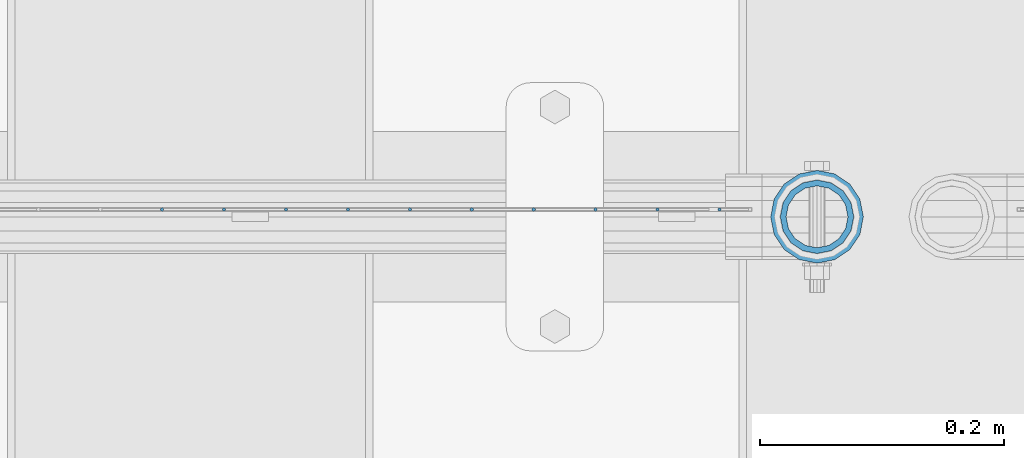
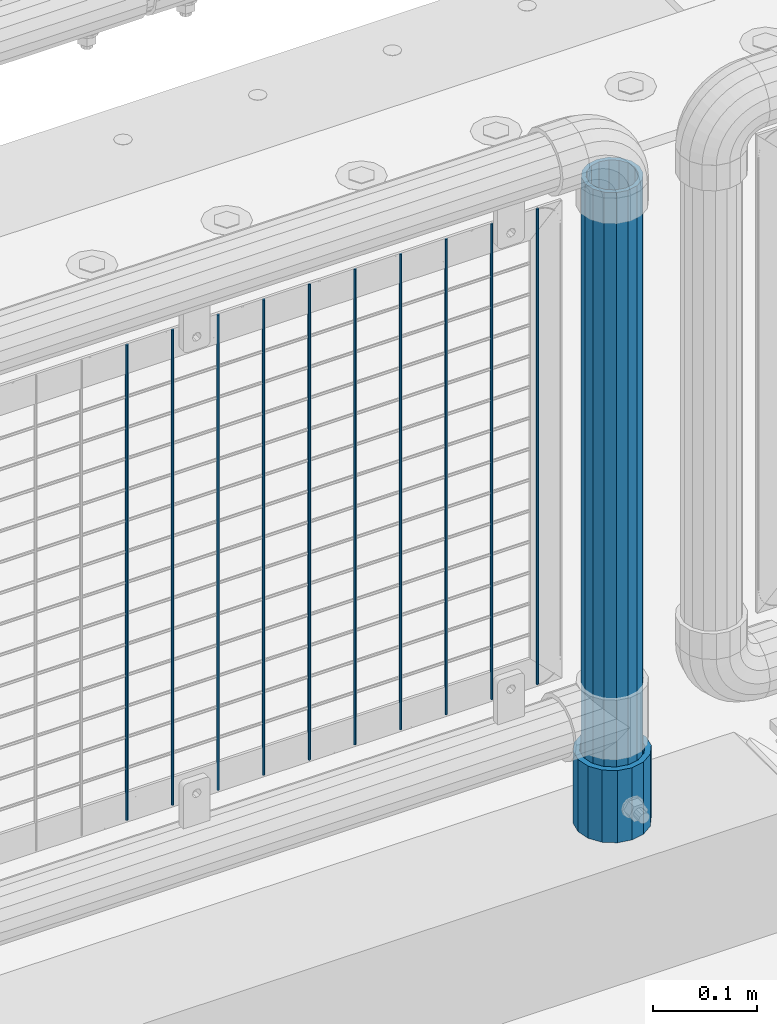
# One storey, part 108 of 270: 12 columns.
"""IFC2X3 building model written with IfcOpenShell, lengths in millimetres."""

from ifc_helpers import new_model, si_unit, frame, origin_with_axes, place, context, subcontext, project, spatial, faceted_brep, material, type_object, element, save


model = new_model("IFC2X3")

# Units and contexts
model_context = context("Model", 3, precision=1e-05, world=origin_with_axes())
body_context = subcontext(model_context, "Body", "Model", "MODEL_VIEW")
ifc_project = project(units=[si_unit("LENGTHUNIT", "METRE", prefix="MILLI"), si_unit("AREAUNIT", "SQUARE_METRE"), si_unit("VOLUMEUNIT", "CUBIC_METRE"), si_unit("MASSUNIT", "GRAM", prefix="KILO"), si_unit("TIMEUNIT", "SECOND"), si_unit("PLANEANGLEUNIT", "RADIAN"), si_unit("SOLIDANGLEUNIT", "STERADIAN"), si_unit("THERMODYNAMICTEMPERATUREUNIT", "DEGREE_CELSIUS"), si_unit("LUMINOUSINTENSITYUNIT", "LUMEN")], contexts=[model_context])

# Site, building, storey
site_placement = place(None, origin_with_axes())
site = spatial("IfcSite", under=ifc_project, at=site_placement, CompositionType="ELEMENT")
building_placement = place(site_placement, origin_with_axes())
building = spatial("IfcBuilding", under=site, at=building_placement, Name="Standard", CompositionType="ELEMENT")
storey_placement = place(building_placement, origin_with_axes())
storey = spatial("IfcBuildingStorey", under=building, at=storey_placement, Name="Undefined", CompositionType="ELEMENT", Elevation=0.0)

# Columns
ifc_material_1 = material()
column_type_1 = type_object("IfcColumnType", PredefinedType="NOTDEFINED")
column_1_placement = place(storey_placement, frame((18583.9999998042, -16335.5, 168.019999999998), z_axis=(-1.0, 0.0, 0.0), x_axis=(0.0, 0.0, 1.0)))
element("IfcColumn", 1, at=column_1_placement, inside=storey, type_object=column_type_1, material=ifc_material_1, context=body_context, shape_type="Brep", body=[
    faceted_brep([(0.0, -25.3500000000004, 0.0), (0.0, -23.4203461491616, 9.70102501045403), (760.0, -23.4203461491616, 9.70102501045403), (760.0, -25.3500000000004, 0.0), (0.0, -17.9251569030785, 17.9251569030785), (760.0, -17.9251569030785, 17.9251569030785), (0.0, -9.70102501045585, 23.4203461491597), (760.0, -9.70102501045585, 23.4203461491597), (0.0, 0.0, 25.3499999999985), (760.0, 0.0, 25.3499999999985), (0.0, 9.70102501045585, 23.4203461491597), (760.0, 9.70102501045585, 23.4203461491597), (0.0, 17.9251569030785, 17.9251569030785), (760.0, 17.9251569030785, 17.9251569030785), (0.0, 23.4203461491616, 9.70102501045403), (760.0, 23.4203461491616, 9.70102501045403), (0.0, 25.3500000000004, 0.0), (760.0, 25.3500000000004, 0.0), (0.0, 23.4203461491616, -9.70102501045403), (760.0, 23.4203461491616, -9.70102501045403), (0.0, 17.9251569030785, -17.9251569030785), (760.0, 17.9251569030785, -17.9251569030785), (0.0, 9.70102501045585, -23.4203461491597), (760.0, 9.70102501045585, -23.4203461491597), (0.0, 0.0, -25.3499999999985), (760.0, 0.0, -25.3499999999985), (0.0, -9.70102501045585, -23.4203461491597), (760.0, -9.70102501045585, -23.4203461491597), (0.0, -17.9251569030785, -17.9251569030785), (760.0, -17.9251569030785, -17.9251569030785), (0.0, -23.4203461491616, -9.70102501045403), (760.0, -23.4203461491616, -9.70102501045403), (0.0, -30.1499999999996, 0.0), (0.0, -27.8549679052157, -11.5379054858058), (760.0, -27.8549679052157, -11.5379054858058), (760.0, -30.1499999999996, 0.0), (0.0, -21.3192694527752, -21.3192694527752), (760.0, -21.3192694527752, -21.3192694527752), (0.0, -11.5379054858076, -27.8549679052157), (760.0, -11.5379054858076, -27.8549679052157), (0.0, 0.0, -30.1500000000015), (760.0, 0.0, -30.1500000000015), (0.0, 11.5379054858076, -27.8549679052157), (760.0, 11.5379054858076, -27.8549679052157), (0.0, 21.3192694527752, -21.3192694527752), (760.0, 21.3192694527752, -21.3192694527752), (0.0, 27.8549679052157, -11.5379054858058), (760.0, 27.8549679052157, -11.5379054858058), (0.0, 30.1499999999996, 0.0), (760.0, 30.1499999999996, 0.0), (0.0, 27.8549679052157, 11.5379054858058), (760.0, 27.8549679052157, 11.5379054858058), (0.0, 21.3192694527752, 21.3192694527752), (760.0, 21.3192694527752, 21.3192694527752), (0.0, 11.5379054858076, 27.8549679052157), (760.0, 11.5379054858076, 27.8549679052157), (0.0, 0.0, 30.1500000000015), (760.0, 0.0, 30.1500000000015), (0.0, -11.5379054858076, 27.8549679052157), (760.0, -11.5379054858076, 27.8549679052157), (0.0, -21.3192694527752, 21.3192694527752), (760.0, -21.3192694527752, 21.3192694527752), (0.0, -27.8549679052157, 11.5379054858058), (760.0, -27.8549679052157, 11.5379054858058)], [[[0, 1, 2, 3]], [[1, 4, 5, 2]], [[4, 6, 7, 5]], [[6, 8, 9, 7]], [[8, 10, 11, 9]], [[10, 12, 13, 11]], [[12, 14, 15, 13]], [[14, 16, 17, 15]], [[16, 18, 19, 17]], [[18, 20, 21, 19]], [[20, 22, 23, 21]], [[22, 24, 25, 23]], [[24, 26, 27, 25]], [[26, 28, 29, 27]], [[28, 30, 31, 29]], [[30, 0, 3, 31]], [[32, 33, 34, 35]], [[33, 36, 37, 34]], [[36, 38, 39, 37]], [[38, 40, 41, 39]], [[40, 42, 43, 41]], [[42, 44, 45, 43]], [[44, 46, 47, 45]], [[46, 48, 49, 47]], [[48, 50, 51, 49]], [[50, 52, 53, 51]], [[52, 54, 55, 53]], [[54, 56, 57, 55]], [[56, 58, 59, 57]], [[58, 60, 61, 59]], [[60, 62, 63, 61]], [[62, 32, 35, 63]], [[37, 39, 41, 43, 45, 47, 49, 51, 53, 55, 57, 59, 61, 63, 35, 34], [5, 7, 9, 11, 13, 15, 17, 19, 21, 23, 25, 27, 29, 31, 3, 2]], [[62, 60, 58, 56, 54, 52, 50, 48, 46, 44, 42, 40, 38, 36, 33, 32], [30, 28, 26, 24, 22, 20, 18, 16, 14, 12, 10, 8, 6, 4, 1, 0]]]),
])
column_type_2 = type_object("IfcColumnType", PredefinedType="NOTDEFINED")
column_2_placement = place(storey_placement, frame((18583.9999998042, -16335.5, 168.019999999998), z_axis=(0.0, 1.0, 0.0), x_axis=(0.0, 0.0, 1.0)))
element("IfcColumn", 2, at=column_2_placement, inside=storey, type_object=column_type_2, material=ifc_material_1, context=body_context, shape_type="Brep", body=[
    faceted_brep([(0.0, -31.75, 0.0), (0.0, -29.3331751572332, 12.1501989775916), (85.0, -29.3331751572332, 12.1501989775916), (85.0, -31.75, 0.0), (0.0, -22.4506403026717, 22.4506403026735), (85.0, -22.4506403026717, 22.4506403026735), (0.0, -12.1501989775934, 29.3331751572332), (85.0, -12.1501989775934, 29.3331751572332), (0.0, 0.0, 31.75), (85.0, 0.0, 31.75), (0.0, 12.1501989775934, 29.3331751572332), (85.0, 12.1501989775934, 29.3331751572332), (0.0, 22.4506403026717, 22.4506403026735), (85.0, 22.4506403026717, 22.4506403026735), (0.0, 29.3331751572332, 12.1501989775916), (85.0, 29.3331751572332, 12.1501989775916), (0.0, 31.75, 0.0), (85.0, 31.75, 0.0), (0.0, 29.3331751572332, -12.1501989775916), (85.0, 29.3331751572332, -12.1501989775916), (0.0, 22.4506403026717, -22.4506403026735), (85.0, 22.4506403026717, -22.4506403026735), (0.0, 12.1501989775934, -29.3331751572332), (85.0, 12.1501989775934, -29.3331751572332), (0.0, 0.0, -31.75), (85.0, 0.0, -31.75), (0.0, -12.1501989775934, -29.3331751572332), (85.0, -12.1501989775934, -29.3331751572332), (0.0, -22.4506403026717, -22.4506403026735), (85.0, -22.4506403026717, -22.4506403026735), (0.0, -29.3331751572332, -12.1501989775916), (85.0, -29.3331751572332, -12.1501989775916), (0.0, -38.0499999999993, 0.0), (0.0, -35.1536162120537, -14.561104601491), (85.0, -35.1536162120537, -14.561104601491), (85.0, -38.0499999999993, 0.0), (0.0, -26.9054130241493, -26.9054130241475), (85.0, -26.9054130241493, -26.9054130241475), (0.0, -14.5611046014928, -35.1536162120537), (85.0, -14.5611046014928, -35.1536162120537), (0.0, 0.0, -38.0499999999993), (85.0, 0.0, -38.0499999999993), (0.0, 14.5611046014928, -35.1536162120537), (85.0, 14.5611046014928, -35.1536162120537), (0.0, 26.9054130241493, -26.9054130241475), (85.0, 26.9054130241493, -26.9054130241475), (0.0, 35.1536162120537, -14.561104601491), (85.0, 35.1536162120537, -14.561104601491), (0.0, 38.0499999999993, 0.0), (85.0, 38.0499999999993, 0.0), (0.0, 35.1536162120537, 14.561104601491), (85.0, 35.1536162120537, 14.561104601491), (0.0, 26.9054130241493, 26.9054130241475), (85.0, 26.9054130241493, 26.9054130241475), (0.0, 14.5611046014928, 35.1536162120537), (85.0, 14.5611046014928, 35.1536162120537), (0.0, 0.0, 38.0499999999993), (85.0, 0.0, 38.0499999999993), (0.0, -14.5611046014928, 35.1536162120537), (85.0, -14.5611046014928, 35.1536162120537), (0.0, -26.9054130241493, 26.9054130241475), (85.0, -26.9054130241493, 26.9054130241475), (0.0, -35.1536162120537, 14.561104601491), (85.0, -35.1536162120537, 14.561104601491)], [[[0, 1, 2, 3]], [[1, 4, 5, 2]], [[4, 6, 7, 5]], [[6, 8, 9, 7]], [[8, 10, 11, 9]], [[10, 12, 13, 11]], [[12, 14, 15, 13]], [[14, 16, 17, 15]], [[16, 18, 19, 17]], [[18, 20, 21, 19]], [[20, 22, 23, 21]], [[22, 24, 25, 23]], [[24, 26, 27, 25]], [[26, 28, 29, 27]], [[28, 30, 31, 29]], [[30, 0, 3, 31]], [[32, 33, 34, 35]], [[33, 36, 37, 34]], [[36, 38, 39, 37]], [[38, 40, 41, 39]], [[40, 42, 43, 41]], [[42, 44, 45, 43]], [[44, 46, 47, 45]], [[46, 48, 49, 47]], [[48, 50, 51, 49]], [[50, 52, 53, 51]], [[52, 54, 55, 53]], [[54, 56, 57, 55]], [[56, 58, 59, 57]], [[58, 60, 61, 59]], [[60, 62, 63, 61]], [[62, 32, 35, 63]], [[37, 39, 41, 43, 45, 47, 49, 51, 53, 55, 57, 59, 61, 63, 35, 34], [5, 7, 9, 11, 13, 15, 17, 19, 21, 23, 25, 27, 29, 31, 3, 2]], [[62, 60, 58, 56, 54, 52, 50, 48, 46, 44, 42, 40, 38, 36, 33, 32], [30, 28, 26, 24, 22, 20, 18, 16, 14, 12, 10, 8, 6, 4, 1, 0]]]),
])
ifc_material_2 = material(Name="Misc_Undefined")
column_type_3 = type_object("IfcColumnType", Name="D3", PredefinedType="NOTDEFINED")
for number, where, z_axis, x_axis in (
    (3, (18453.204, -16329.5, 353.02), (-1.0, 0.0, 0.0), (0.0, 0.0, 1.0)),
    (4, (18402.411, -16329.5, 353.02), (-1.0, 0.0, 0.0), (0.0, 0.0, 1.0)),
    (5, (18351.618, -16329.5, 353.02), (-1.0, 0.0, 0.0), (0.0, 0.0, 1.0)),
    (6, (18300.825, -16329.5, 353.02), (-1.0, 0.0, 0.0), (0.0, 0.0, 1.0)),
    (7, (18250.032, -16329.5, 353.02), (-1.0, 0.0, 0.0), (0.0, 0.0, 1.0)),
    (8, (18199.239, -16329.5, 353.02), (-1.0, 0.0, 0.0), (0.0, 0.0, 1.0)),
    (9, (18148.446, -16329.5, 353.02), (-1.0, 0.0, 0.0), (0.0, 0.0, 1.0)),
    (10, (18503.997, -16329.5, 353.02), (-1.0, 0.0, 0.0), (0.0, 0.0, 1.0)),
    (11, (18097.653, -16329.5, 353.02), (-1.0, 0.0, 0.0), (0.0, 0.0, 1.0)),
    (12, (18046.86, -16329.5, 353.02), (-1.0, 0.0, 0.0), (0.0, 0.0, 1.0)),
):
    element("IfcColumn", number, at=place(storey_placement, frame(where, z_axis=z_axis, x_axis=x_axis)), inside=storey, type_object=column_type_3, material=ifc_material_2, ObjectType="D3", context=body_context, shape_type="Brep", body=[
        faceted_brep([(0.0, -1.5, 0.0), (0.0, -0.75, -1.29903810567669), (560.0, -0.75, -1.29903810567703), (560.0, -1.5, 0.0), (0.0, 0.75, -1.29903810567669), (560.0, 0.75, -1.29903810567703), (0.0, 1.5, 0.0), (560.0, 1.5, 0.0), (0.0, 0.75, 1.29903810567669), (560.0, 0.75, 1.29903810567703), (0.0, -0.75, 1.29903810567669), (560.0, -0.75, 1.29903810567703)], [[[0, 1, 2, 3]], [[1, 4, 5, 2]], [[4, 6, 7, 5]], [[6, 8, 9, 7]], [[8, 10, 11, 9]], [[10, 0, 3, 11]], [[5, 7, 9, 11, 3, 2]], [[10, 8, 6, 4, 1, 0]]]),
    ])

save(model, "model.ifc")
